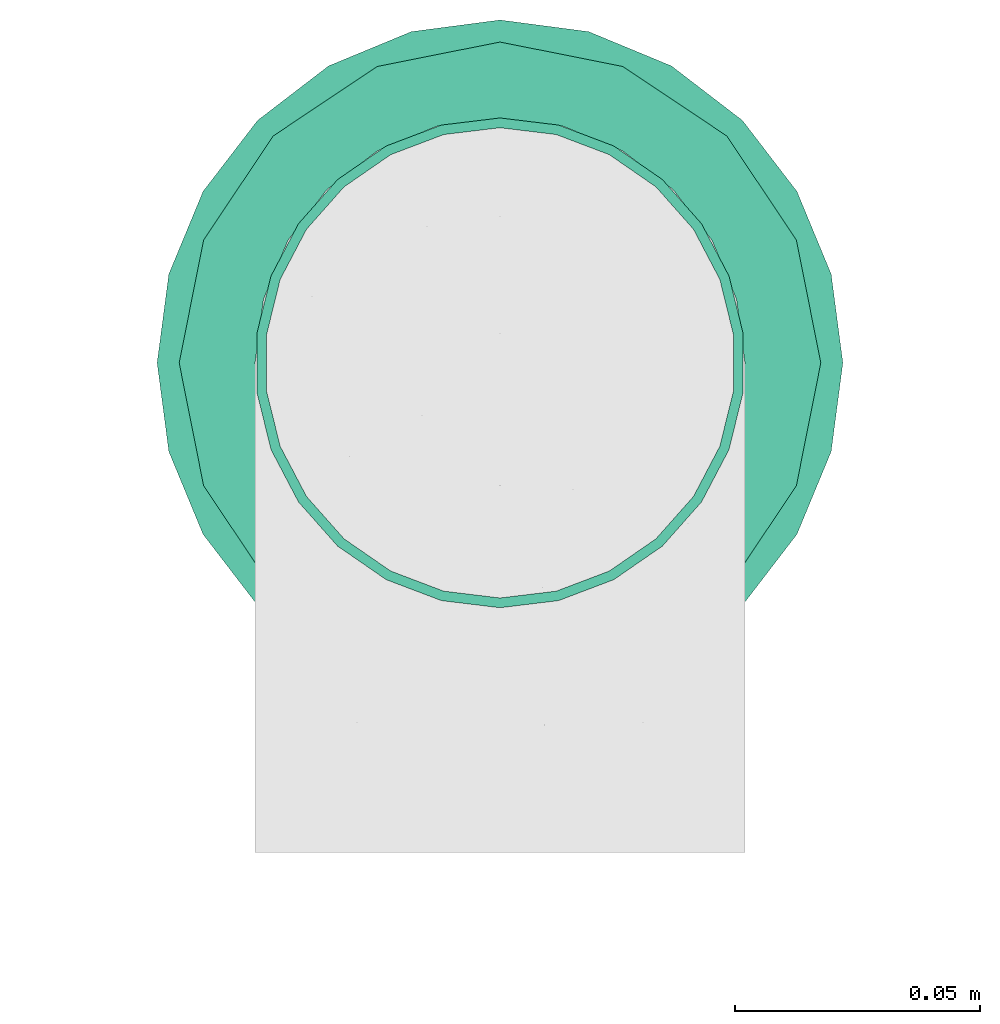
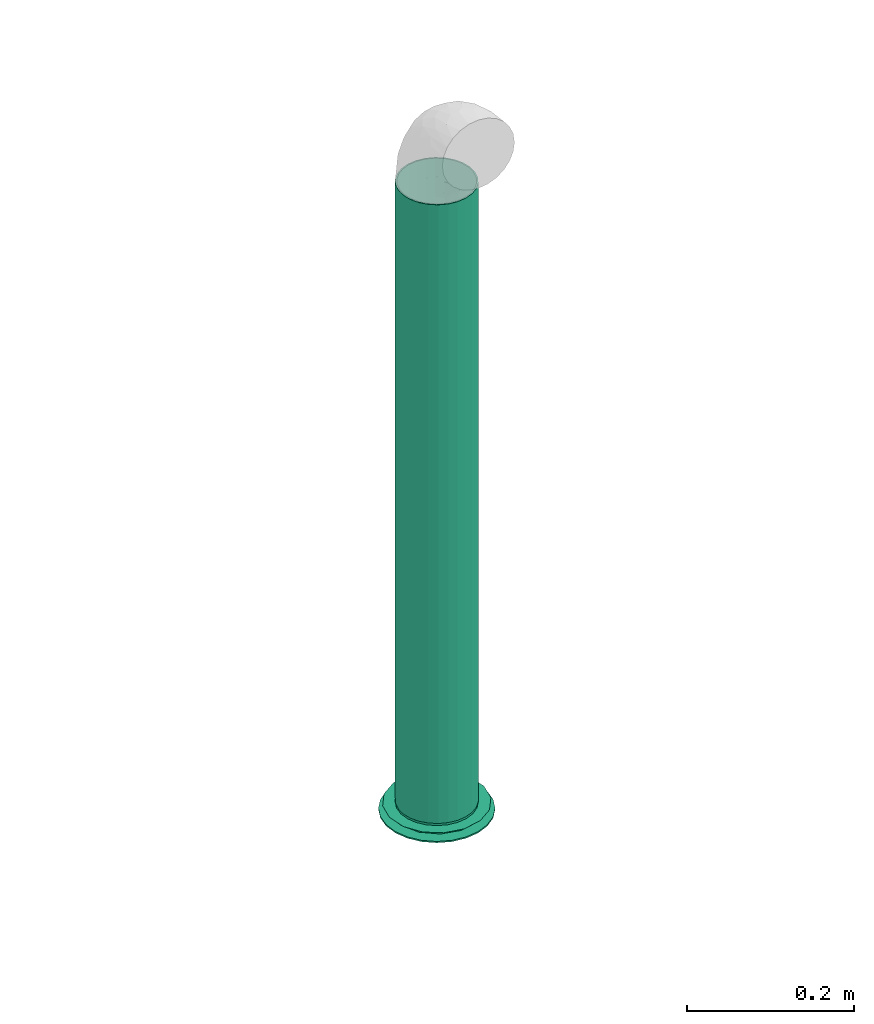
# One storey, part 39 of 103: 1 flow segment, 1 flow terminal.
"""IFC2X3 building model written with IfcOpenShell, lengths in millimetres."""

from ifc_helpers import new_model, entity, si_unit, converted_unit, derived_unit, direction, frame, origin_with_axes, origin_2d_with_axis, place, context, subcontext, project, spatial, hollow_circle, extrude, open_shell, surface_model, source, transform, mapped, material, layer, layer_set, layer_usage, type_object, element, save


model = new_model("IFC2X3")

# Units and contexts
model_context = context("Model", 3, precision=1e-05, world=origin_with_axes(), true_north=direction((0.0, 1.0)))
body_context = subcontext(model_context, "Body", "Model", "MODEL_VIEW")
ifc_project = project(units=[si_unit("AREAUNIT", "SQUARE_METRE"), si_unit("VOLUMEUNIT", "CUBIC_METRE", prefix="DECI"), si_unit("TIMEUNIT", "SECOND"), si_unit("THERMODYNAMICTEMPERATUREUNIT", "DEGREE_CELSIUS"), si_unit("PRESSUREUNIT", "PASCAL"), si_unit("MASSUNIT", "GRAM", prefix="KILO"), si_unit("LENGTHUNIT", "METRE", prefix="MILLI"), si_unit("POWERUNIT", "WATT"), si_unit("ELECTRICCURRENTUNIT", "AMPERE"), si_unit("ELECTRICVOLTAGEUNIT", "VOLT"), derived_unit("VOLUMETRICFLOWRATEUNIT", [(si_unit("VOLUMEUNIT", "CUBIC_METRE", prefix="DECI"), 1), (si_unit("TIMEUNIT", "SECOND"), -1)]), derived_unit("LINEARVELOCITYUNIT", [(si_unit("LENGTHUNIT", "METRE"), 1), (si_unit("TIMEUNIT", "SECOND"), -1)]), derived_unit("MASSDENSITYUNIT", [(si_unit("MASSUNIT", "GRAM", prefix="KILO"), 1), (si_unit("VOLUMEUNIT", "CUBIC_METRE"), -1)]), converted_unit("PLANEANGLEUNIT", "DEGREE", entity("IfcRatioMeasure", 0.01745), si_unit("PLANEANGLEUNIT", "RADIAN"), dimensions=[0, 0, 0, 0, 0, 0, 0])], contexts=[model_context])

# Site, building, storey
site_placement = place(None, origin_with_axes())
site = spatial("IfcSite", under=ifc_project, at=site_placement, CompositionType="ELEMENT")
building_placement = place(site_placement, origin_with_axes())
building = spatial("IfcBuilding", under=site, at=building_placement, Name="mc-building", CompositionType="ELEMENT")
storey_placement = place(building_placement, frame((0.0, 0.0, 5900.0), z_axis=(0.0, 0.0, 1.0), x_axis=(1.0, 0.0, 0.0)))
storey = spatial("IfcBuildingStorey", under=building, at=storey_placement, Name="3. Korrus", CompositionType="ELEMENT", Elevation=5900.0)

# Flow terminal
air_terminal_type = type_object("IfcAirTerminalType", Name="100", PredefinedType="NOTDEFINED")
shared_shape_1 = source(origin_with_axes(), body_context, "Body", "SurfaceModel", [
    surface_model("IfcShellBasedSurfaceModel", [(11.2, 18.11733, -67.61481), (11.2, -18.11733, -67.61481), (11.2, 0.0, -70.0), (11.2, 67.61481, -18.11733), (11.2, 35.0, -60.62178), (11.2, 49.49747, -49.49747), (11.2, 60.62178, -35.0), (11.2, -67.61481, 18.11733), (11.2, -49.49747, -49.49747), (11.2, -67.61481, -18.11733), (11.2, -35.0, -60.62178), (11.2, -60.62178, -35.0), (11.2, -70.0, 0.0), (11.2, 18.11733, 67.61481), (11.2, 70.0, 0.0), (11.2, 67.61481, 18.11733), (11.2, 49.49747, 49.49747), (11.2, 60.62178, 35.0), (11.2, 35.0, 60.62178), (11.2, -49.49747, 49.49747), (11.2, -60.62178, 35.0), (11.2, -35.0, 60.62178), (11.2, -18.11733, 67.61481), (11.2, 0.0, 70.0), (9.2, 18.11733, 67.61481), (9.2, -67.61481, 18.11733), (9.2, 0.0, 70.0), (9.2, 49.49747, 49.49747), (9.2, 35.0, 60.62178), (9.2, 60.62178, 35.0), (9.2, 67.61481, 18.11733), (9.2, -35.0, 60.62178), (9.2, -49.49747, 49.49747), (9.2, -18.11733, 67.61481), (9.2, -60.62178, 35.0), (9.2, -67.61481, -18.11733), (9.2, -70.0, 0.0), (9.2, 67.61481, -18.11733), (9.2, 18.11733, -67.61481), (9.2, 49.49747, -49.49747), (9.2, 60.62178, -35.0), (9.2, 35.0, -60.62178), (9.2, -18.11733, -67.61481), (9.2, -49.49747, -49.49747), (9.2, -60.62178, -35.0), (9.2, -35.0, -60.62178), (9.2, 0.0, -70.0), (9.2, 70.0, 0.0), (9.2, 32.75, 0.0), (9.2, -16.375, 28.36233), (9.2, -28.36233, 16.375), (9.2, 16.375, 28.36233), (9.2, 0.0, 32.75), (9.2, 28.36233, 16.375), (9.2, -32.75, 0.0), (9.2, -16.375, -28.36233), (9.2, 16.375, -28.36233), (9.2, 0.0, -32.75), (9.2, 28.36233, -16.375), (9.2, -28.36233, -16.375), (6.2, -21.19625, -15.39997), (6.2, -21.19625, 15.39997), (6.2, 8.09625, 24.91768), (6.2, -8.09625, 24.91768), (6.2, -26.2, 0.0), (6.2, 21.19625, 15.39997), (6.2, -8.09625, -24.91768), (6.2, 21.19625, -15.39997), (6.2, 8.09625, -24.91768), (6.2, 26.2, 0.0), (9.2, 31.06579, -6.28555), (6.2, 23.69812, -7.69999), (6.2, -14.64625, -20.15883), (9.2, -22.36867, -22.36867), (6.2, -23.69812, -7.69999), (9.2, -31.06579, -6.28555), (6.2, 14.64625, -20.15883), (9.2, 8.1875, -30.55617), (6.2, 0.0, -24.91768), (9.2, 22.36867, -22.36867), (9.2, -8.1875, -30.55617), (9.2, -31.06579, 6.28555), (6.2, -23.69812, 7.69999), (6.2, 14.64625, 20.15883), (9.2, 22.36867, 22.36867), (6.2, 23.69812, 7.69999), (9.2, 31.06579, 6.28555), (6.2, -14.64625, 20.15883), (9.2, -8.1875, 30.55617), (6.2, 0.0, 24.91768), (9.2, -22.36867, 22.36867), (9.2, 8.1875, 30.55617), (6.2, -13.11761, 57.472), (6.2, -36.75472, 46.08897), (6.2, -53.11211, 25.57744), (6.2, 36.75472, 46.08897), (6.2, -58.95, 0.0), (6.2, 13.11761, 57.472), (6.2, 53.11211, 25.57744), (6.2, -53.11211, -25.57744), (6.2, -36.75472, -46.08897), (6.2, -13.11761, -57.472), (6.2, 58.95, 0.0), (6.2, 53.11211, -25.57744), (6.2, 13.11761, -57.472), (6.2, 36.75472, -46.08897), (0.0, -60.51411, 25.06576), (0.0, 0.0, 65.5), (0.0, 25.06576, 60.51411), (0.0, 46.3155, 46.3155), (0.0, 60.51411, 25.06576), (0.0, -46.3155, 46.3155), (0.0, -25.06576, 60.51411), (0.0, 0.0, -65.5), (0.0, -65.5, 0.0), (0.0, 65.5, 0.0), (0.0, 60.51411, -25.06576), (0.0, 46.3155, -46.3155), (0.0, 25.06576, -60.51411), (0.0, -46.3155, -46.3155), (0.0, -60.51411, -25.06576), (0.0, -25.06576, -60.51411), (6.2, 56.03105, -12.78872), (0.0, 53.4148, -35.69063), (0.0, 35.69063, -53.4148), (6.2, 24.93616, -51.78048), (0.0, -12.53288, -63.00706), (6.2, 0.0, -57.472), (0.0, -35.69063, -53.4148), (0.0, 63.00706, -12.53288), (6.2, 44.93342, -35.83321), (6.2, -24.93616, -51.78048), (6.2, -44.93342, -35.83321), (0.0, -53.4148, -35.69063), (0.0, 12.53288, -63.00706), (6.2, -56.03105, -12.78872), (0.0, -63.00706, -12.53288), (6.2, -56.03105, 12.78872), (0.0, -53.4148, 35.69063), (0.0, -35.69063, 53.4148), (6.2, -24.93616, 51.78048), (0.0, 12.53288, 63.00706), (6.2, 0.0, 57.472), (0.0, 35.69063, 53.4148), (0.0, -63.00706, 12.53288), (6.2, -44.93342, 35.83321), (6.2, 24.93616, 51.78048), (6.2, 44.93342, 35.83321), (0.0, 53.4148, 35.69063), (0.0, -12.53288, 63.00706), (6.2, 56.03105, 12.78872), (0.0, 63.00706, 12.53288), (-3.1, 12.94095, 48.29629), (-3.1, -35.35534, 35.35534), (-3.1, 0.0, 50.0), (-3.1, 35.35534, 35.35534), (-3.1, 25.0, 43.30127), (-3.1, -43.30127, 25.0), (-3.1, 43.30127, 25.0), (-3.1, -48.29629, -12.94095), (-3.1, -12.94095, 48.29629), (-3.1, -25.0, 43.30127), (-3.1, -50.0, 0.0), (-3.1, -48.29629, 12.94095), (-3.1, 48.29629, 12.94095), (-3.1, 12.94095, -48.29629), (-3.1, 50.0, 0.0), (-3.1, 48.29629, -12.94095), (-3.1, 35.35534, -35.35534), (-3.1, 43.30127, -25.0), (-3.1, 25.0, -43.30127), (-3.1, 0.0, -50.0), (-3.1, -35.35534, -35.35534), (-3.1, -43.30127, -25.0), (-3.1, -25.0, -43.30127), (-3.1, -12.94095, -48.29629), (0.0, 25.0, -43.30127), (0.0, 0.0, -50.0), (0.0, 12.94095, -48.29629), (0.0, 48.29629, -12.94095), (0.0, 35.35534, -35.35534), (0.0, -25.0, -43.30127), (0.0, 43.30127, -25.0), (0.0, -50.0, 0.0), (0.0, -12.94095, -48.29629), (0.0, -35.35534, -35.35534), (0.0, -48.29629, -12.94095), (0.0, -43.30127, -25.0), (0.0, 50.0, 0.0), (0.0, 43.30127, 25.0), (0.0, 12.94095, 48.29629), (0.0, 35.35534, 35.35534), (0.0, 25.0, 43.30127), (0.0, 0.0, 50.0), (0.0, -35.35534, 35.35534), (0.0, -43.30127, 25.0), (0.0, -48.29629, 12.94095), (0.0, -12.94095, 48.29629), (0.0, -25.0, 43.30127), (0.0, 48.29629, 12.94095), (-43.1, 0.0, 45.0), (-43.1, 11.64686, 43.46666), (-43.1, 22.5, 38.97115), (-43.1, -11.64686, 43.46666), (-43.1, 38.97115, 22.5), (-43.1, 43.46666, 11.64686), (-43.1, 31.81981, 31.81981), (-43.1, -22.5, 38.97115), (-43.1, -43.46666, 11.64686), (-43.1, -31.81981, 31.81981), (-43.1, -38.97115, 22.5), (-43.1, -45.0, 0.0), (-43.1, -43.46666, -11.64686), (-43.1, 45.0, 0.0), (-43.1, 43.46666, -11.64686), (-43.1, 38.97115, -22.5), (-43.1, 31.81981, -31.81981), (-43.1, 22.5, -38.97115), (-43.1, 11.64686, -43.46666), (-43.1, -31.81981, -31.81981), (-43.1, -38.97115, -22.5), (-43.1, -22.5, -38.97115), (-43.1, 0.0, -45.0), (-43.1, -11.64686, -43.46666), (-3.1, 22.5, -38.97115), (-3.1, 0.0, -45.0), (-3.1, 11.64686, -43.46666), (-3.1, 31.81981, -31.81981), (-3.1, -22.5, -38.97115), (-3.1, 38.97115, -22.5), (-3.1, 43.46666, -11.64686), (-3.1, 45.0, 0.0), (-3.1, -45.0, 0.0), (-3.1, -11.64686, -43.46666), (-3.1, -31.81981, -31.81981), (-3.1, -43.46666, -11.64686), (-3.1, -38.97115, -22.5), (-3.1, 0.0, 45.0), (-3.1, 43.46666, 11.64686), (-3.1, 38.97115, 22.5), (-3.1, 22.5, 38.97115), (-3.1, 31.81981, 31.81981), (-3.1, 11.64686, 43.46666), (-3.1, -11.64686, 43.46666), (-3.1, -43.46666, 11.64686), (-3.1, -31.81981, 31.81981), (-3.1, -38.97115, 22.5), (-3.1, -22.5, 38.97115)], [open_shell([[[0, 1, 2]], [[3, 0, 4]], [[5, 6, 3]], [[5, 3, 4]], [[7, 1, 0]], [[8, 7, 9]], [[10, 7, 8]], [[8, 9, 11]], [[12, 9, 7]], [[1, 7, 10]], [[7, 0, 3]], [[13, 14, 15]], [[16, 15, 17]], [[16, 18, 13]], [[16, 13, 15]], [[14, 13, 7]], [[7, 19, 20]], [[19, 7, 21]], [[7, 22, 21]], [[22, 7, 23]], [[7, 13, 23]], [[14, 7, 3]], [[24, 25, 26]], [[27, 24, 28]], [[27, 29, 30]], [[27, 30, 24]], [[25, 24, 30]], [[31, 25, 32]], [[25, 31, 33]], [[32, 25, 34]], [[33, 26, 25]], [[25, 35, 36]], [[25, 30, 37]], [[25, 37, 38]], [[39, 37, 40]], [[39, 41, 38]], [[39, 38, 37]], [[38, 42, 25]], [[35, 43, 44]], [[35, 25, 43]], [[45, 43, 25]], [[42, 45, 25]], [[38, 46, 42]], [[37, 30, 47]], [[35, 9, 36]], [[44, 11, 35]], [[10, 43, 45]], [[44, 43, 8]], [[1, 45, 42]], [[35, 11, 9]], [[9, 12, 36]], [[1, 10, 45]], [[8, 43, 10]], [[8, 11, 44]], [[2, 1, 42]], [[42, 46, 2]], [[38, 0, 46]], [[41, 4, 38]], [[6, 39, 40]], [[41, 39, 5]], [[3, 40, 37]], [[41, 5, 4]], [[4, 0, 38]], [[14, 3, 37]], [[6, 40, 3]], [[6, 5, 39]], [[47, 14, 37]], [[46, 0, 2]], [[30, 15, 47]], [[29, 17, 30]], [[18, 27, 28]], [[29, 27, 16]], [[13, 28, 24]], [[30, 17, 15]], [[15, 14, 47]], [[13, 18, 28]], [[16, 27, 18]], [[16, 17, 29]], [[23, 13, 24]], [[24, 26, 23]], [[33, 22, 26]], [[31, 21, 33]], [[20, 32, 34]], [[31, 32, 19]], [[7, 34, 25]], [[31, 19, 21]], [[21, 22, 33]], [[12, 7, 25]], [[20, 34, 7]], [[20, 19, 32]], [[36, 12, 25]], [[26, 22, 23]], [[48, 49, 50]], [[48, 51, 49]], [[49, 51, 52]], [[53, 51, 48]], [[48, 50, 54]], [[54, 55, 48]], [[56, 55, 57]], [[55, 58, 48]], [[58, 55, 56]], [[55, 54, 59]], [[60, 61, 62]], [[62, 61, 63]], [[64, 61, 60]], [[62, 65, 66]], [[67, 68, 65]], [[66, 60, 62]], [[65, 68, 66]], [[69, 67, 65]], [[69, 48, 70]], [[58, 71, 70]], [[72, 73, 60]], [[59, 74, 60]], [[75, 64, 74]], [[56, 68, 76]], [[72, 66, 55]], [[73, 72, 55]], [[68, 77, 78]], [[64, 75, 54]], [[59, 75, 74]], [[70, 71, 69]], [[67, 79, 76]], [[80, 55, 66]], [[68, 56, 77]], [[56, 76, 79]], [[79, 67, 58]], [[71, 58, 67]], [[80, 78, 57]], [[77, 57, 78]], [[66, 78, 80]], [[59, 60, 73]], [[64, 54, 81]], [[50, 82, 81]], [[83, 84, 65]], [[53, 85, 65]], [[86, 69, 85]], [[49, 63, 87]], [[83, 62, 51]], [[84, 83, 51]], [[63, 88, 89]], [[69, 86, 48]], [[53, 86, 85]], [[81, 82, 64]], [[61, 90, 87]], [[91, 51, 62]], [[63, 49, 88]], [[49, 87, 90]], [[90, 61, 50]], [[82, 50, 61]], [[91, 89, 52]], [[88, 52, 89]], [[62, 89, 91]], [[53, 65, 84]], [[92, 93, 94]], [[95, 94, 96]], [[97, 92, 95]], [[95, 92, 94]], [[96, 98, 95]], [[96, 99, 98]], [[99, 100, 101]], [[101, 102, 98]], [[102, 101, 103]], [[104, 105, 103]], [[101, 104, 103]], [[101, 98, 99]], [[106, 107, 108]], [[109, 110, 108]], [[106, 108, 110]], [[111, 112, 106]], [[106, 112, 107]], [[106, 113, 114]], [[106, 110, 113]], [[115, 116, 117]], [[117, 113, 110]], [[113, 117, 118]], [[114, 119, 120]], [[121, 119, 114]], [[121, 114, 113]], [[115, 117, 110]], [[103, 116, 122]], [[123, 116, 103]], [[124, 125, 118]], [[101, 126, 127]], [[100, 119, 128]], [[102, 122, 129]], [[103, 130, 123]], [[102, 129, 115]], [[113, 127, 126]], [[125, 124, 105]], [[130, 105, 117]], [[118, 125, 104]], [[124, 117, 105]], [[131, 100, 128]], [[119, 100, 132]], [[133, 99, 120]], [[134, 118, 104]], [[122, 116, 129]], [[127, 134, 104]], [[131, 121, 101]], [[99, 133, 132]], [[128, 121, 131]], [[130, 117, 123]], [[101, 121, 126]], [[99, 135, 120]], [[96, 136, 135]], [[136, 120, 135]], [[134, 127, 113]], [[133, 119, 132]], [[136, 96, 114]], [[94, 106, 137]], [[138, 106, 94]], [[139, 140, 112]], [[97, 141, 142]], [[95, 109, 143]], [[96, 137, 144]], [[94, 145, 138]], [[96, 144, 114]], [[107, 142, 141]], [[140, 139, 93]], [[145, 93, 111]], [[112, 140, 92]], [[139, 111, 93]], [[146, 95, 143]], [[109, 95, 147]], [[148, 98, 110]], [[149, 112, 92]], [[137, 106, 144]], [[142, 149, 92]], [[146, 108, 97]], [[98, 148, 147]], [[143, 108, 146]], [[145, 111, 138]], [[97, 108, 141]], [[98, 150, 110]], [[102, 151, 150]], [[151, 110, 150]], [[149, 142, 107]], [[148, 109, 147]], [[151, 102, 115]], [[152, 153, 154]], [[155, 152, 156]], [[157, 152, 158]], [[158, 152, 155]], [[158, 159, 157]], [[160, 153, 161]], [[160, 154, 153]], [[157, 162, 163]], [[153, 152, 157]], [[157, 159, 162]], [[158, 164, 159]], [[165, 166, 167]], [[168, 167, 169]], [[170, 165, 167]], [[170, 167, 168]], [[166, 165, 171]], [[159, 172, 173]], [[172, 159, 174]], [[174, 171, 175]], [[159, 164, 174]], [[166, 171, 174]], [[174, 164, 166]], [[176, 177, 178]], [[179, 176, 180]], [[176, 179, 181]], [[179, 180, 182]], [[179, 183, 181]], [[177, 181, 184]], [[177, 176, 181]], [[185, 186, 187]], [[186, 185, 181]], [[181, 183, 186]], [[183, 179, 188]], [[183, 188, 189]], [[190, 189, 191]], [[189, 190, 183]], [[190, 191, 192]], [[193, 194, 190]], [[183, 195, 196]], [[183, 190, 195]], [[194, 197, 198]], [[194, 195, 190]], [[197, 194, 193]], [[189, 188, 199]], [[164, 199, 166]], [[158, 189, 164]], [[192, 155, 156]], [[158, 155, 191]], [[190, 156, 152]], [[164, 189, 199]], [[199, 188, 166]], [[190, 192, 156]], [[191, 155, 192]], [[191, 189, 158]], [[193, 190, 152]], [[152, 154, 193]], [[160, 197, 154]], [[161, 198, 160]], [[195, 153, 157]], [[161, 153, 194]], [[196, 157, 163]], [[161, 194, 198]], [[198, 197, 160]], [[183, 196, 163]], [[195, 157, 196]], [[195, 194, 153]], [[162, 183, 163]], [[154, 197, 193]], [[159, 186, 162]], [[173, 187, 159]], [[181, 172, 174]], [[173, 172, 185]], [[184, 174, 175]], [[159, 187, 186]], [[186, 183, 162]], [[184, 181, 174]], [[185, 172, 181]], [[185, 187, 173]], [[177, 184, 175]], [[175, 171, 177]], [[165, 178, 171]], [[170, 176, 165]], [[182, 168, 169]], [[170, 168, 180]], [[179, 169, 167]], [[170, 180, 176]], [[176, 178, 165]], [[188, 179, 167]], [[182, 169, 179]], [[182, 180, 168]], [[166, 188, 167]], [[171, 178, 177]], [[200, 201, 202]], [[203, 200, 202]], [[204, 205, 202]], [[204, 202, 206]], [[203, 202, 205]], [[207, 208, 209]], [[207, 203, 205]], [[209, 208, 210]], [[211, 208, 212]], [[208, 207, 212]], [[207, 205, 212]], [[213, 214, 215]], [[205, 215, 212]], [[212, 216, 217]], [[216, 212, 215]], [[218, 219, 217]], [[212, 219, 220]], [[212, 217, 219]], [[221, 222, 223]], [[222, 221, 219]], [[218, 222, 219]], [[215, 205, 213]], [[224, 225, 226]], [[227, 228, 224]], [[229, 230, 231]], [[228, 227, 229]], [[229, 232, 228]], [[225, 228, 233]], [[225, 224, 228]], [[234, 235, 236]], [[235, 234, 228]], [[228, 232, 235]], [[232, 229, 231]], [[237, 238, 239]], [[240, 239, 241]], [[240, 242, 237]], [[240, 237, 239]], [[238, 237, 243]], [[244, 245, 246]], [[247, 244, 232]], [[244, 247, 245]], [[232, 238, 247]], [[238, 243, 247]], [[238, 232, 231]], [[205, 238, 213]], [[204, 239, 205]], [[240, 206, 202]], [[204, 206, 241]], [[242, 202, 201]], [[205, 239, 238]], [[238, 231, 213]], [[240, 202, 242]], [[241, 206, 240]], [[241, 239, 204]], [[201, 237, 242]], [[201, 200, 237]], [[243, 203, 207]], [[209, 247, 207]], [[246, 210, 208]], [[209, 210, 245]], [[244, 208, 211]], [[203, 243, 200]], [[207, 247, 243]], [[200, 243, 237]], [[209, 245, 247]], [[210, 246, 245]], [[244, 246, 208]], [[211, 232, 244]], [[212, 235, 211]], [[220, 236, 212]], [[228, 219, 221]], [[220, 219, 234]], [[233, 221, 223]], [[212, 236, 235]], [[235, 232, 211]], [[233, 228, 221]], [[234, 219, 228]], [[234, 236, 220]], [[225, 233, 223]], [[223, 222, 225]], [[226, 218, 217]], [[216, 224, 217]], [[229, 215, 214]], [[216, 215, 227]], [[230, 214, 213]], [[218, 226, 222]], [[217, 224, 226]], [[222, 226, 225]], [[216, 227, 224]], [[215, 229, 227]], [[230, 229, 214]], [[213, 231, 230]]])]),
])
flow_terminal_placement = place(storey_placement, frame((9369.95588, 12733.41275, 2458.87044), z_axis=(1.0, 0.0, 0.0), x_axis=(0.0, 0.0, -1.0)))
element("IfcFlowTerminal", 1, at=flow_terminal_placement, inside=storey, type_object=air_terminal_type, Name="100", context=body_context, shape_type="MappedRepresentation", body=[
    mapped(shared_shape_1, transform((0.0, 0.0, 0.0), scale=1.0)),
])

# Flow segment
ifc_material = material(Name="FZ1")
ifc_layer = layer(ifc_material, 0.0)
ifc_layer_set = layer_set([ifc_layer], Name="FZ1")
ifc_layer_usage = layer_usage(ifc_layer_set, "AXIS1", "POSITIVE", 0.0)
duct_segment_type = type_object("IfcDuctSegmentType", PredefinedType="RIGIDSEGMENT")
shared_shape_2 = source(origin_with_axes(), body_context, "Body", "SweptSolid", [
    extrude(hollow_circle(Radius=50.0, WallThickness=2.0, at=origin_2d_with_axis()), frame((0.0, 0.0, 0.0), z_axis=(1.0, 0.0, 0.0), x_axis=(0.0, 1.0, 0.0)), (0.0, 0.0, 1.0), 906.0),
])
flow_segment_placement = place(storey_placement, frame((9369.95588, 12733.41275, 2461.97044), z_axis=(1.0, 0.0, 0.0), x_axis=(0.0, 0.0, 1.0)))
element("IfcFlowSegment", 2, at=flow_segment_placement, inside=storey, type_object=duct_segment_type, material=ifc_layer_usage, context=body_context, shape_type="MappedRepresentation", body=[
    mapped(shared_shape_2, transform((0.0, 0.0, 0.0), scale=1.0)),
])

save(model, "model.ifc")
